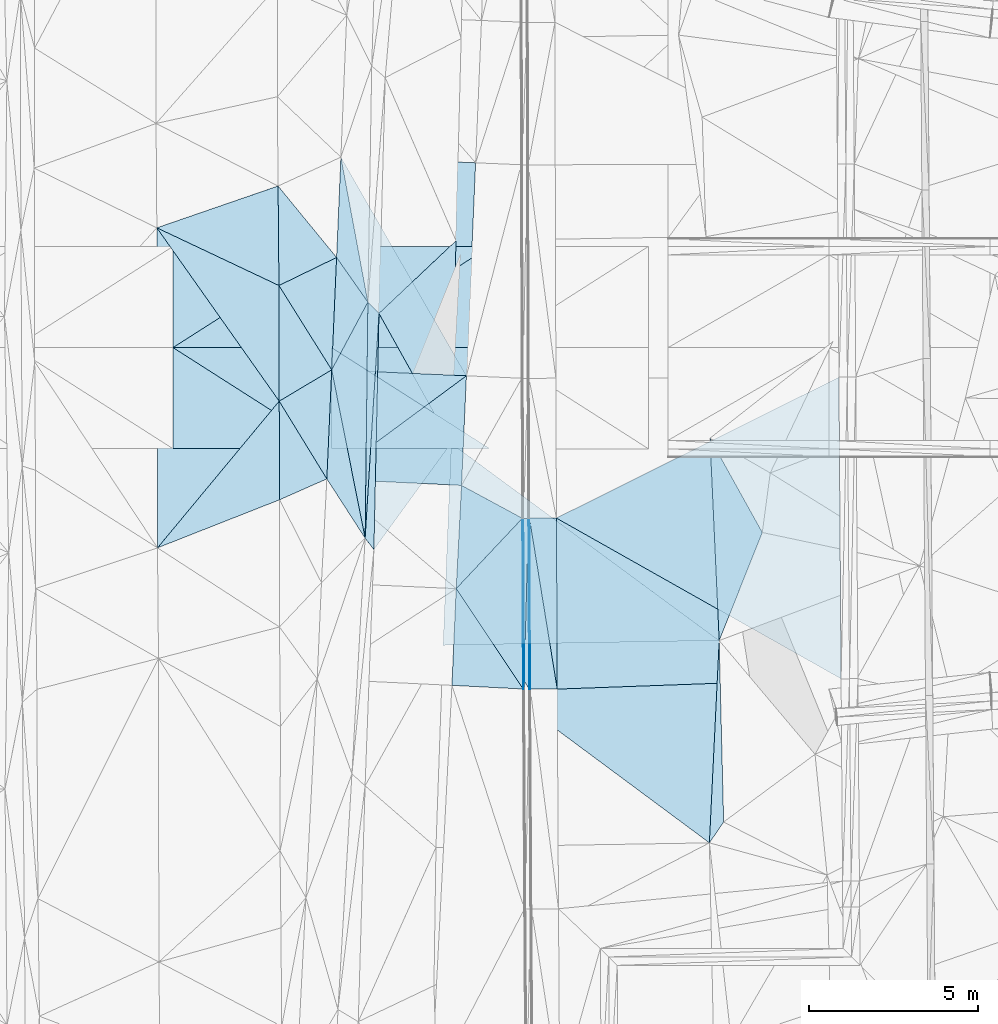
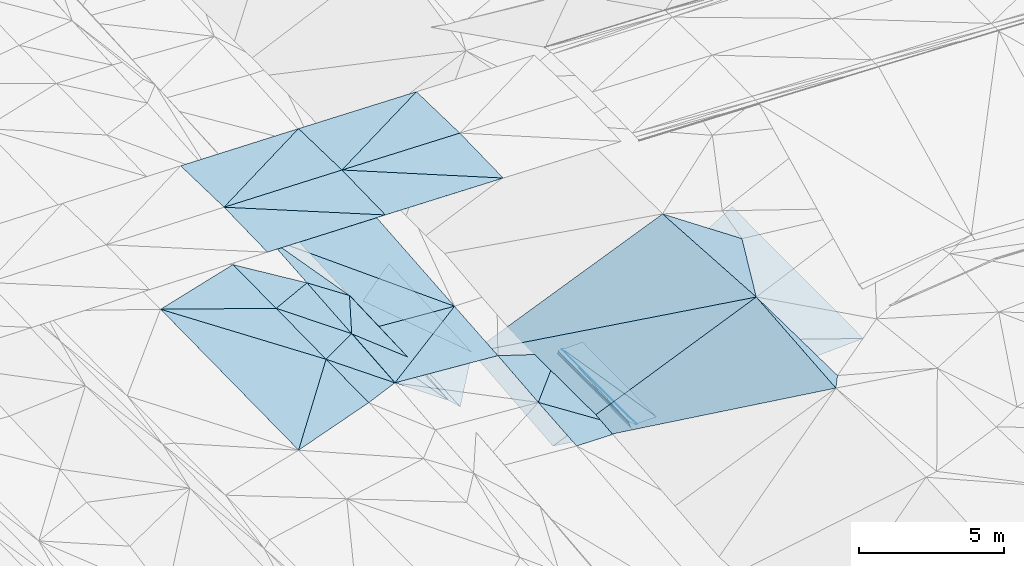
# One storey, part 96 of 275: 47 plates.
"""IFC2X3 building model written with IfcOpenShell, lengths in millimetres."""

from ifc_helpers import new_model, si_unit, frame, origin_with_axes, place, context, subcontext, project, spatial, polyline, outline, extrude, material, type_object, element, save


model = new_model("IFC2X3")

# Units and contexts
model_context = context("Model", 3, precision=1e-05, world=origin_with_axes())
body_context = subcontext(model_context, "Body", "Model", "MODEL_VIEW")
ifc_project = project(units=[si_unit("LENGTHUNIT", "METRE", prefix="MILLI"), si_unit("AREAUNIT", "SQUARE_METRE"), si_unit("VOLUMEUNIT", "CUBIC_METRE"), si_unit("MASSUNIT", "GRAM", prefix="KILO"), si_unit("TIMEUNIT", "SECOND"), si_unit("PLANEANGLEUNIT", "RADIAN"), si_unit("SOLIDANGLEUNIT", "STERADIAN"), si_unit("THERMODYNAMICTEMPERATUREUNIT", "DEGREE_CELSIUS"), si_unit("LUMINOUSINTENSITYUNIT", "LUMEN")], contexts=[model_context])

# Site, building, storey
site_placement = place(None, origin_with_axes())
site = spatial("IfcSite", under=ifc_project, at=site_placement, CompositionType="ELEMENT")
building_placement = place(site_placement, origin_with_axes())
building = spatial("IfcBuilding", under=site, at=building_placement, Name="Undefined", CompositionType="ELEMENT")
storey_placement = place(building_placement, origin_with_axes())
storey = spatial("IfcBuildingStorey", under=building, at=storey_placement, Name="Undefined", CompositionType="ELEMENT", Elevation=0.0)

# Plates
ifc_material = material()
plate_type_1 = type_object("IfcPlateType", PredefinedType="NOTDEFINED")
plate_1_placement = place(storey_placement, frame((-57543.422501909, 53163.1614883886, 42166.4393151958), z_axis=(0.031081005307814, 0.0169940351680346, -0.99937238999172), x_axis=(-0.998218742855956, 0.0514695879660527, -0.0301699009888954)))
element("IfcPlate", 1, at=plate_1_placement, inside=storey, type_object=plate_type_1, material=ifc_material, Name="00_PR", context=body_context, shape_type="SweptSolid", body=[
    extrude(outline(polyline([(0.0, 0.0), (2118.1044921875, -6.38829078525305e-09), (2137.24145507813, 2872.6474609375), (0.0, 0.0)])), frame((-8.85201319254618e-08, 2.18876761149539e-07, -0.5000001331573), z_axis=(0.0, 0.0, 1.0), x_axis=(1.0, 0.0, 0.0)), (0.0, 0.0, 1.0), 1.0),
])
plate_type_2 = type_object("IfcPlateType", PredefinedType="NOTDEFINED")
plate_2_placement = place(storey_placement, frame((-62950.6827658772, 68939.227915002, 42539.500382228), z_axis=(-0.03169918662069, 0.022843660801364, -0.99923637280114), x_axis=(0.998587986680233, -0.0419150259997993, -0.0326368419635838)))
element("IfcPlate", 2, at=plate_2_placement, inside=storey, type_object=plate_type_2, material=ifc_material, Name="00_PR", context=body_context, shape_type="SweptSolid", body=[
    extrude(outline(polyline([(0.0, 0.0), (4002.13354492188, -1.1859810911119e-08), (3999.06005859375, 6324.34912109375), (0.0, 0.0)])), frame((-8.85201319254618e-08, 2.18876761149539e-07, -0.5000001331573), z_axis=(0.0, 0.0, 1.0), x_axis=(1.0, 0.0, 0.0)), (0.0, 0.0, 1.0), 1.0),
])
plate_type_3 = type_object("IfcPlateType", PredefinedType="NOTDEFINED")
plate_3_placement = place(storey_placement, frame((-57566.8014895133, 58227.8968345423, 42252.821652203), z_axis=(0.970062529157908, 0.00866256078734789, -0.242700740757766), x_axis=(0.24268760909219, 0.0025521390305167, 0.970101134407895)))
element("IfcPlate", 3, at=plate_3_placement, inside=storey, type_object=plate_type_3, material=ifc_material, Name="00_PR", context=body_context, shape_type="SweptSolid", body=[
    extrude(outline(polyline([(0.0, 0.0), (123.607734680176, -1.38243194669485e-10), (37.2168807983398, 4822.37939453125), (0.0, 0.0)])), frame((-8.85201319254618e-08, 2.18876761149539e-07, -0.5000001331573), z_axis=(0.0, 0.0, 1.0), x_axis=(1.0, 0.0, 0.0)), (0.0, 0.0, 1.0), 1.0),
])
plate_type_4 = type_object("IfcPlateType", PredefinedType="NOTDEFINED")
plate_4_placement = place(storey_placement, frame((-57387.2881771584, 58228.6731265302, 42372.3550749499), z_axis=(-5.17628773639704e-05, 0.0170027214714135, -0.999855441943069), x_axis=(-0.0264140459897011, -0.999506605183952, -0.016995421974935)))
element("IfcPlate", 4, at=plate_4_placement, inside=storey, type_object=plate_type_4, material=ifc_material, Name="00_PR", context=body_context, shape_type="SweptSolid", body=[
    extrude(outline(polyline([(0.0, 0.0), (4825.24072265625, 1.666194293648e-09), (4.4185471534729, 149.935913085938), (0.0, 0.0)])), frame((-8.85201319254618e-08, 2.18876761149539e-07, -0.5000001331573), z_axis=(0.0, 0.0, 1.0), x_axis=(1.0, 0.0, 0.0)), (0.0, 0.0, 1.0), 1.0),
])
plate_5_placement = place(storey_placement, frame((-57514.7420254048, 53405.8131487874, 42290.348075249), z_axis=(0.000512374739449698, 0.0169878150610855, -0.999855565375108), x_axis=(0.0264140459544826, 0.999506605184821, 0.0169954219785252)))
element("IfcPlate", 5, at=plate_5_placement, inside=storey, type_object=plate_type_4, material=ifc_material, Name="00_PR", context=body_context, shape_type="SweptSolid", body=[
    extrude(outline(polyline([(0.0, 0.0), (4825.24072265625, 1.666194293648e-09), (-244.948867797852, 157.864486694336), (0.0, 0.0)])), frame((-8.85201319254618e-08, 2.18876761149539e-07, -0.5000001331573), z_axis=(0.0, 0.0, 1.0), x_axis=(1.0, 0.0, 0.0)), (0.0, 0.0, 1.0), 1.0),
])
plate_type_5 = type_object("IfcPlateType", PredefinedType="NOTDEFINED")
plate_6_placement = place(storey_placement, frame((-57357.2782605059, 58228.8013939178, 42372.955173437), z_axis=(0.0199201727534585, 0.0170759017334811, -0.999655740891564), x_axis=(0.00470861303382416, -0.999844652207322, -0.0169852999890066)))
element("IfcPlate", 6, at=plate_6_placement, inside=storey, type_object=plate_type_5, material=ifc_material, Name="00_PR", context=body_context, shape_type="SweptSolid", body=[
    extrude(outline(polyline([(0.0, 0.0), (5072.62158203125, 3.40514816343784e-09), (-0.00285750813782215, 30.0062046051025), (0.0, 0.0)])), frame((-8.85201319254618e-08, 2.18876761149539e-07, -0.5000001331573), z_axis=(0.0, 0.0, 1.0), x_axis=(1.0, 0.0, 0.0)), (0.0, 0.0, 1.0), 1.0),
])
plate_7_placement = place(storey_placement, frame((-57363.3930375372, 53156.8145658619, 42286.1951750821), z_axis=(0.01990570778941, 0.0170758385226892, -0.999656030110432), x_axis=(-0.00470861303292056, 0.999844652207386, 0.0169852999855012)))
element("IfcPlate", 7, at=plate_7_placement, inside=storey, type_object=plate_type_5, material=ifc_material, Name="00_PR", context=body_context, shape_type="SweptSolid", body=[
    extrude(outline(polyline([(0.0, 0.0), (5072.646484375, -6.50470610707998e-09), (0.0222192071378231, 30.006160736084), (0.0, 0.0)])), frame((-8.85201319254618e-08, 2.18876761149539e-07, -0.5000001331573), z_axis=(0.0, 0.0, 1.0), x_axis=(1.0, 0.0, 0.0)), (0.0, 0.0, 1.0), 1.0),
])
plate_type_6 = type_object("IfcPlateType", PredefinedType="NOTDEFINED")
plate_8_placement = place(storey_placement, frame((-59226.8680623683, 62454.4673304758, 42273.1193965442), z_axis=(-0.0331318692391955, 0.022019806860911, -0.999208390350344), x_axis=(-0.998452220315106, 0.0439548420281208, 0.0340754399842334)))
element("IfcPlate", 8, at=plate_8_placement, inside=storey, type_object=plate_type_6, material=ifc_material, Name="00_PR", context=body_context, shape_type="SweptSolid", body=[
    extrude(outline(polyline([(0.0, 0.0), (4002.32543945313, 5.51517587155104e-09), (4012.16552734375, 6316.04345703125), (0.0, 0.0)])), frame((-8.85201319254618e-08, 2.18876761149539e-07, -0.5000001331573), z_axis=(0.0, 0.0, 1.0), x_axis=(1.0, 0.0, 0.0)), (0.0, 0.0, 1.0), 1.0),
])
plate_type_7 = type_object("IfcPlateType", PredefinedType="NOTDEFINED")
plate_9_placement = place(storey_placement, frame((-59226.8681075771, 62454.4663267547, 42273.1193769358), z_axis=(-0.0332215681213128, 0.0200126804531088, -0.999247626983744), x_axis=(-0.804247836515456, -0.594108741626347, 0.0148398309750414)))
element("IfcPlate", 9, at=plate_9_placement, inside=storey, type_object=plate_type_7, material=ifc_material, Name="00_PR", context=body_context, shape_type="SweptSolid", body=[
    extrude(outline(polyline([(0.0, 0.0), (5148.3740234375, 9.10949893295765e-09), (3111.38671875, 2517.51489257813), (0.0, 0.0)])), frame((-8.85201319254618e-08, 2.18876761149539e-07, -0.5000001331573), z_axis=(0.0, 0.0, 1.0), x_axis=(1.0, 0.0, 0.0)), (0.0, 0.0, 1.0), 1.0),
])
plate_type_8 = type_object("IfcPlateType", PredefinedType="NOTDEFINED")
plate_10_placement = place(storey_placement, frame((-48178.7023094388, 62412.346601848, 42627.1131726756), z_axis=(0.0198965623516011, 0.0170739529141056, -0.999656244385277), x_axis=(0.00717861900447163, -0.999830838280169, -0.0169340560163154)))
element("IfcPlate", 10, at=plate_10_placement, inside=storey, type_object=plate_type_8, material=ifc_material, Name="00_PR", context=body_context, shape_type="SweptSolid", body=[
    extrude(outline(polyline([(0.0, 0.0), (8947.4130859375, -3.28873284161091e-09), (4123.2958984375, 8410.064453125), (0.0, 0.0)])), frame((-8.85201319254618e-08, 2.18876761149539e-07, -0.5000001331573), z_axis=(0.0, 0.0, 1.0), x_axis=(1.0, 0.0, 0.0)), (0.0, 0.0, 1.0), 1.0),
])
plate_type_9 = type_object("IfcPlateType", PredefinedType="NOTDEFINED")
plate_11_placement = place(storey_placement, frame((-56557.285949707, 58232.2299351179, 42388.955173764), z_axis=(0.0199201142362082, 0.01707817588788, -0.999655703208439), x_axis=(0.00470870499317034, -0.99984461315807, -0.016987572989571)))
element("IfcPlate", 11, at=plate_11_placement, inside=storey, type_object=plate_type_9, material=ifc_material, Name="00_PR", context=body_context, shape_type="SweptSolid", body=[
    extrude(outline(polyline([(0.0, 0.0), (5071.94287109375, -9.66247171163559e-09), (-0.0671199709177017, 800.159606933594), (0.0, 0.0)])), frame((-8.85201319254618e-08, 2.18876761149539e-07, -0.5000001331573), z_axis=(0.0, 0.0, 1.0), x_axis=(1.0, 0.0, 0.0)), (0.0, 0.0, 1.0), 1.0),
])
plate_12_placement = place(storey_placement, frame((-57333.3932574569, 53156.9678758025, 42286.7951734155), z_axis=(0.01990570778941, 0.0170758385226892, -0.999656030110432), x_axis=(-0.00470861303292056, 0.999844652207386, 0.0169852999855012)))
element("IfcPlate", 12, at=plate_12_placement, inside=storey, type_object=plate_type_9, material=ifc_material, Name="00_PR", context=body_context, shape_type="SweptSolid", body=[
    extrude(outline(polyline([(0.0, 0.0), (5072.62158203125, 3.40514816343784e-09), (0.61169171333313, 800.159851074219), (0.0, 0.0)])), frame((-8.85201319254618e-08, 2.18876761149539e-07, -0.5000001331573), z_axis=(0.0, 0.0, 1.0), x_axis=(1.0, 0.0, 0.0)), (0.0, 0.0, 1.0), 1.0),
])
plate_type_10 = type_object("IfcPlateType", PredefinedType="NOTDEFINED")
plate_13_placement = place(storey_placement, frame((-56533.4036791864, 53161.0752837046, 42302.7951735082), z_axis=(0.0198988933770571, 0.0170780831592164, -0.999656127434817), x_axis=(-0.00470870499390485, 0.999844613158034, 0.0169875729914905)))
element("IfcPlate", 13, at=plate_13_placement, inside=storey, type_object=plate_type_10, material=ifc_material, Name="00_PR", context=body_context, shape_type="SweptSolid", body=[
    extrude(outline(polyline([(0.0, 0.0), (5071.94287109375, -9.66247171163559e-09), (268.617309570313, 8421.95703125), (0.0, 0.0)])), frame((-8.85201319254618e-08, 2.18876761149539e-07, -0.5000001331573), z_axis=(0.0, 0.0, 1.0), x_axis=(1.0, 0.0, 0.0)), (0.0, 0.0, 1.0), 1.0),
])
plate_type_11 = type_object("IfcPlateType", PredefinedType="NOTDEFINED")
plate_14_placement = place(storey_placement, frame((-57514.2571233091, 53405.8089911216, 42290.7271543364), z_axis=(0.97031300291252, 0.00867317983337593, -0.24169702590323), x_axis=(-0.104742525963713, -0.885703765879199, -0.452280711905942)))
element("IfcPlate", 14, at=plate_14_placement, inside=storey, type_object=plate_type_11, material=ifc_material, Name="00_PR", context=body_context, shape_type="SweptSolid", body=[
    extrude(outline(polyline([(0.0, 0.0), (273.964813232422, 8.65838956087828e-10), (-4248.2939453125, 2282.26342773438), (0.0, 0.0)])), frame((-8.85201319254618e-08, 2.18876761149539e-07, -0.5000001331573), z_axis=(0.0, 0.0, 1.0), x_axis=(1.0, 0.0, 0.0)), (0.0, 0.0, 1.0), 1.0),
])
plate_type_12 = type_object("IfcPlateType", PredefinedType="NOTDEFINED")
plate_15_placement = place(storey_placement, frame((-63367.4366735568, 59395.772322673, 42349.5203750867), z_axis=(-0.0331540178362152, 0.0199211355243714, -0.999251699753739), x_axis=(0.804247836488412, 0.594108741662183, -0.0148398310060044)))
element("IfcPlate", 15, at=plate_15_placement, inside=storey, type_object=plate_type_12, material=ifc_material, Name="00_PR", context=body_context, shape_type="SweptSolid", body=[
    extrude(outline(polyline([(0.0, 0.0), (5148.3740234375, 9.10949893295765e-09), (3100.84399414063, 2530.52880859375), (0.0, 0.0)])), frame((-8.85201319254618e-08, 2.18876761149539e-07, -0.5000001331573), z_axis=(0.0, 0.0, 1.0), x_axis=(1.0, 0.0, 0.0)), (0.0, 0.0, 1.0), 1.0),
])
plate_type_13 = type_object("IfcPlateType", PredefinedType="NOTDEFINED")
plate_16_placement = place(storey_placement, frame((-57567.2709646403, 58227.9011385298, 42252.4433178087), z_axis=(0.0311068829844818, 0.0172670337245296, -0.999366905284213), x_axis=(-0.68491724292521, -0.727832072964979, -0.0338945999715446)))
element("IfcPlate", 16, at=plate_16_placement, inside=storey, type_object=plate_type_13, material=ifc_material, Name="00_PR", context=body_context, shape_type="SweptSolid", body=[
    extrude(outline(polyline([(0.0, 0.0), (2866.47436523438, -6.54836185276508e-10), (527.645446777344, 1982.75134277344), (0.0, 0.0)])), frame((-8.85201319254618e-08, 2.18876761149539e-07, -0.5000001331573), z_axis=(0.0, 0.0, 1.0), x_axis=(1.0, 0.0, 0.0)), (0.0, 0.0, 1.0), 1.0),
])
plate_type_14 = type_object("IfcPlateType", PredefinedType="NOTDEFINED")
plate_17_placement = place(storey_placement, frame((-59530.5685744037, 56141.589114218, 42155.2853190807), z_axis=(0.0312658129850754, 0.0171173635819324, -0.999364520484086), x_axis=(0.68491724293034, 0.72783207296017, 0.033894599971146)))
element("IfcPlate", 17, at=plate_17_placement, inside=storey, type_object=plate_type_14, material=ifc_material, Name="00_PR", context=body_context, shape_type="SweptSolid", body=[
    extrude(outline(polyline([(0.0, 0.0), (2866.47436523438, -6.54836185276508e-10), (-806.386352539063, 3488.501953125), (0.0, 0.0)])), frame((-8.85201319254618e-08, 2.18876761149539e-07, -0.5000001331573), z_axis=(0.0, 0.0, 1.0), x_axis=(1.0, 0.0, 0.0)), (0.0, 0.0, 1.0), 1.0),
])
plate_type_15 = type_object("IfcPlateType", PredefinedType="NOTDEFINED")
plate_18_placement = place(storey_placement, frame((-51730.2493647922, 54601.7923780748, 44799.5010316709), z_axis=(0.0643825779679155, -0.00388626777522607, -0.997917722348383), x_axis=(-0.0455081325727989, 0.998940644659639, -0.00682629597379633)))
element("IfcPlate", 18, at=plate_18_placement, inside=storey, type_object=plate_type_15, material=ifc_material, Name="00", context=body_context, shape_type="SweptSolid", body=[
    extrude(outline(polyline([(0.0, 0.0), (6006.18505859375, 1.06228981167078e-08), (3142.517578125, 1425.86987304688), (0.0, 0.0)])), frame((-8.85201319254618e-08, 2.18876761149539e-07, -0.5000001331573), z_axis=(0.0, 0.0, 1.0), x_axis=(1.0, 0.0, 0.0)), (0.0, 0.0, 1.0), 1.0),
])
plate_type_16 = type_object("IfcPlateType", PredefinedType="NOTDEFINED")
plate_19_placement = place(storey_placement, frame((-63078.3658798046, 65963.4929968548, 42479.5003329321), z_axis=(-0.0295994415330011, 0.0222714215108826, -0.999313692913701), x_axis=(0.573916397487466, -0.818155599567758, -0.0352332739172863)))
element("IfcPlate", 19, at=plate_19_placement, inside=storey, type_object=plate_type_16, material=ifc_material, Name="00", context=body_context, shape_type="SweptSolid", body=[
    extrude(outline(polyline([(0.0, 0.0), (1617.78894042969, -2.57205101661384e-09), (2646.45776367188, 2032.64892578125), (0.0, 0.0)])), frame((-8.85201319254618e-08, 2.18876761149539e-07, -0.5000001331573), z_axis=(0.0, 0.0, 1.0), x_axis=(1.0, 0.0, 0.0)), (0.0, 0.0, 1.0), 1.0),
])
plate_type_17 = type_object("IfcPlateType", PredefinedType="NOTDEFINED")
plate_20_placement = place(storey_placement, frame((-62950.6824021428, 68939.227258617, 42539.5003415751), z_axis=(-0.0307436325685577, 0.0214680683097768, -0.999296728254194), x_axis=(0.183044588702285, -0.982740783305995, -0.0267438100114988)))
element("IfcPlate", 20, at=plate_20_placement, inside=storey, type_object=plate_type_17, material=ifc_material, Name="00", context=body_context, shape_type="SweptSolid", body=[
    extrude(outline(polyline([(0.0, 0.0), (4374.84423828125, 5.70435076951981e-09), (2902.60864257813, 670.644104003906), (0.0, 0.0)])), frame((-8.85201319254618e-08, 2.18876761149539e-07, -0.5000001331573), z_axis=(0.0, 0.0, 1.0), x_axis=(1.0, 0.0, 0.0)), (0.0, 0.0, 1.0), 1.0),
])
plate_type_18 = type_object("IfcPlateType", PredefinedType="NOTDEFINED")
plate_21_placement = place(storey_placement, frame((-63230.6143020348, 60290.5260598626, 48834.5112211787), z_axis=(-0.0164056946686971, 0.0249897670495609, -0.999553082494995), x_axis=(-0.999865308224511, 5.74249800787707e-05, 0.0164122549174482)))
element("IfcPlate", 21, at=plate_21_placement, inside=storey, type_object=plate_type_18, material=ifc_material, Name="00_PR", context=body_context, shape_type="SweptSolid", body=[
    extrude(outline(polyline([(0.0, 0.0), (4700.6337890625, 9.69885149970651e-09), (4701.865234375, 3000.93701171875), (0.0, 0.0)])), frame((-8.85201319254618e-08, 2.18876761149539e-07, -0.5000001331573), z_axis=(0.0, 0.0, 1.0), x_axis=(1.0, 0.0, 0.0)), (0.0, 0.0, 1.0), 1.0),
])
for number, where, z_axis, x_axis, name in (
    (22, (-58530.2717067931, 66290.2320981999, 48745.0862443468), (-0.0190186426029315, -0.0249865816732146, -0.999506859391085), (-5.7277968073799e-05, -0.999687644772795, 0.0249921909375039), "00_PR"),
    (23, (-63230.4437249566, 63290.5010943905, 48909.5112436928), (-0.0190186426029315, -0.0249865816732146, -0.999506859391085), (5.72779774420735e-05, 0.999687644773175, -0.0249921909222736), "00_PR"),
):
    element("IfcPlate", number, at=place(storey_placement, frame(where, z_axis=z_axis, x_axis=x_axis)), inside=storey, type_object=plate_type_18, material=ifc_material, Name=name, context=body_context, shape_type="SweptSolid", body=[
        extrude(outline(polyline([(0.0, 0.0), (3000.9375, -1.02954800240695e-08), (3003.17260742188, 4700.85009765625), (0.0, 0.0)])), frame((-8.85201319254618e-08, 2.18876761149539e-07, -0.5000001331573), z_axis=(0.0, 0.0, 1.0), x_axis=(1.0, 0.0, 0.0)), (0.0, 0.0, 1.0), 1.0),
    ])
for number, where, z_axis, x_axis, name in (
    (24, (-63230.2705378828, 66290.5011156195, 48834.5112205392), (-0.0164085654338146, -0.0249878867924049, -0.999553082379347), (-5.7277968073799e-05, -0.999687644772795, 0.0249921909375039), "00_PR"),
    (25, (-67930.4429602772, 63290.7710249563, 48986.6592201924), (-0.0164085654338146, -0.0249878867924049, -0.999553082379347), (5.72779774420735e-05, 0.999687644773175, -0.0249921909222736), "00_PR"),
):
    element("IfcPlate", number, at=place(storey_placement, frame(where, z_axis=z_axis, x_axis=x_axis)), inside=storey, type_object=plate_type_18, material=ifc_material, Name=name, context=body_context, shape_type="SweptSolid", body=[
        extrude(outline(polyline([(0.0, 0.0), (3000.9375, -1.02954800240695e-08), (3002.86474609375, 4700.63330078125), (0.0, 0.0)])), frame((-8.85201319254618e-08, 2.18876761149539e-07, -0.5000001331573), z_axis=(0.0, 0.0, 1.0), x_axis=(1.0, 0.0, 0.0)), (0.0, 0.0, 1.0), 1.0),
    ])
for number, where, z_axis, x_axis, name in (
    (26, (-58530.6154680566, 60290.2570415009, 48745.0862434874), (-0.0190157818601353, 0.024988761145131, -0.999506859334482), (-0.999819041835124, 5.72269654439282e-05, 0.0190231519199148), "00_PR"),
    (27, (-63230.4437224018, 63290.5260817592, 48909.5112435177), (-0.0190157818601353, 0.024988761145131, -0.999506859334482), (0.999819041835124, -5.72279615117681e-05, -0.0190231519169448), "00_PR"),
):
    element("IfcPlate", number, at=place(storey_placement, frame(where, z_axis=z_axis, x_axis=x_axis)), inside=storey, type_object=plate_type_18, material=ifc_material, Name=name, context=body_context, shape_type="SweptSolid", body=[
        extrude(outline(polyline([(0.0, 0.0), (4700.8505859375, 7.67613528296351e-09), (4702.27734375, 3000.93701171875), (0.0, 0.0)])), frame((-8.85201319254618e-08, 2.18876761149539e-07, -0.5000001331573), z_axis=(0.0, 0.0, 1.0), x_axis=(1.0, 0.0, 0.0)), (0.0, 0.0, 1.0), 1.0),
    ])
plate_22_placement = place(storey_placement, frame((-67930.4429574338, 63290.7960136694, 48986.6592202172), z_axis=(-0.0164056946686971, 0.0249897670495609, -0.999553082494995), x_axis=(0.999865308224479, -5.74239653362821e-05, -0.0164122549229329)))
element("IfcPlate", 28, at=plate_22_placement, inside=storey, type_object=plate_type_18, material=ifc_material, Name="00_PR", context=body_context, shape_type="SweptSolid", body=[
    extrude(outline(polyline([(0.0, 0.0), (4700.6337890625, 9.69885149970651e-09), (4701.865234375, 3000.93701171875), (0.0, 0.0)])), frame((-8.85201319254618e-08, 2.18876761149539e-07, -0.5000001331573), z_axis=(0.0, 0.0, 1.0), x_axis=(1.0, 0.0, 0.0)), (0.0, 0.0, 1.0), 1.0),
])
plate_type_19 = type_object("IfcPlateType", PredefinedType="NOTDEFINED")
plate_23_placement = place(storey_placement, frame((-61821.2891481645, 64304.1834579537, 42280.5589304288), z_axis=(-0.47003751701198, 0.0302416941933889, -0.882128206403993), x_axis=(-0.0214625264551516, -0.999508963645156, -0.0228296200394951)))
element("IfcPlate", 29, at=plate_23_placement, inside=storey, type_object=plate_type_19, material=ifc_material, Name="00", context=body_context, shape_type="SweptSolid", body=[
    extrude(outline(polyline([(0.0, 0.0), (7008.43896484375, -3.95812094211578e-09), (6672.947265625, 302.559478759766), (0.0, 0.0)])), frame((-8.85201319254618e-08, 2.18876761149539e-07, -0.5000001331573), z_axis=(0.0, 0.0, 1.0), x_axis=(1.0, 0.0, 0.0)), (0.0, 0.0, 1.0), 1.0),
])
plate_type_20 = type_object("IfcPlateType", PredefinedType="NOTDEFINED")
plate_24_placement = place(storey_placement, frame((-52020.677254083, 48600.9546011829, 44701.5000658458), z_axis=(-0.00535935572403004, 0.0165878934871873, -0.999848048003236), x_axis=(0.0483290054063805, 0.998698302159262, 0.0163097670319585)))
element("IfcPlate", 30, at=plate_24_placement, inside=storey, type_object=plate_type_20, material=ifc_material, Name="00", context=body_context, shape_type="SweptSolid", body=[
    extrude(outline(polyline([(0.0, 0.0), (6008.66943359375, 1.15396687760949e-08), (638.599426269531, 392.490447998047), (0.0, 0.0)])), frame((-8.85201319254618e-08, 2.18876761149539e-07, -0.5000001331573), z_axis=(0.0, 0.0, 1.0), x_axis=(1.0, 0.0, 0.0)), (0.0, 0.0, 1.0), 1.0),
])
plate_type_21 = type_object("IfcPlateType", PredefinedType="NOTDEFINED")
plate_25_placement = place(storey_placement, frame((-63223.0013934845, 62630.3880502379, 42409.500455729), z_axis=(-0.0381428293351847, 0.0202352682869509, -0.999067394367198), x_axis=(0.194731881610685, -0.980476705850231, -0.0272932879925005)))
element("IfcPlate", 31, at=plate_25_placement, inside=storey, type_object=plate_type_21, material=ifc_material, Name="00", context=body_context, shape_type="SweptSolid", body=[
    extrude(outline(polyline([(0.0, 0.0), (5092.8271484375, -1.38170435093343e-08), (3144.97607421875, 772.220947265625), (0.0, 0.0)])), frame((-8.85201319254618e-08, 2.18876761149539e-07, -0.5000001331573), z_axis=(0.0, 0.0, 1.0), x_axis=(1.0, 0.0, 0.0)), (0.0, 0.0, 1.0), 1.0),
])
plate_type_22 = type_object("IfcPlateType", PredefinedType="NOTDEFINED")
plate_26_placement = place(storey_placement, frame((-62149.8900607357, 64639.8898096396, 42422.5003267709), z_axis=(-0.029146139573007, 0.0220294713087413, -0.999332379612433), x_axis=(-0.0116160974671641, -0.999697070031031, -0.0216987200314869)))
element("IfcPlate", 32, at=plate_26_placement, inside=storey, type_object=plate_type_22, material=ifc_material, Name="00", context=body_context, shape_type="SweptSolid", body=[
    extrude(outline(polyline([(0.0, 0.0), (7005.021484375, 2.1143932826817e-08), (2021.63952636719, 1050.14025878906), (0.0, 0.0)])), frame((-8.85201319254618e-08, 2.18876761149539e-07, -0.5000001331573), z_axis=(0.0, 0.0, 1.0), x_axis=(1.0, 0.0, 0.0)), (0.0, 0.0, 1.0), 1.0),
])
plate_type_23 = type_object("IfcPlateType", PredefinedType="NOTDEFINED")
plate_27_placement = place(storey_placement, frame((-62231.4340933103, 57636.9917308327, 42270.5366745083), z_axis=(-0.375176197443002, 0.024472190620312, -0.926630418645132), x_axis=(0.0116160974802961, 0.999697070032008, 0.0216987199794335)))
element("IfcPlate", 33, at=plate_27_placement, inside=storey, type_object=plate_type_23, material=ifc_material, Name="00", context=body_context, shape_type="SweptSolid", body=[
    extrude(outline(polyline([(0.0, 0.0), (7005.021484375, 2.1143932826817e-08), (6670.15087890625, 358.9580078125), (0.0, 0.0)])), frame((-8.85201319254618e-08, 2.18876761149539e-07, -0.5000001331573), z_axis=(0.0, 0.0, 1.0), x_axis=(1.0, 0.0, 0.0)), (0.0, 0.0, 1.0), 1.0),
])
plate_type_24 = type_object("IfcPlateType", PredefinedType="NOTDEFINED")
plate_28_placement = place(storey_placement, frame((-63222.9980111179, 62630.3880944803, 42409.5003422572), z_axis=(-0.0313758641808913, 0.0203262907377129, -0.999300954193354), x_axis=(-0.858679197762185, -0.512246445469311, 0.0165412948267589)))
element("IfcPlate", 34, at=plate_28_placement, inside=storey, type_object=plate_type_24, material=ifc_material, Name="00", context=body_context, shape_type="SweptSolid", body=[
    extrude(outline(polyline([(0.0, 0.0), (1813.64270019531, -2.459273673594e-09), (64.2905044555664, 2951.044921875), (0.0, 0.0)])), frame((-8.85201319254618e-08, 2.18876761149539e-07, -0.5000001331573), z_axis=(0.0, 0.0, 1.0), x_axis=(1.0, 0.0, 0.0)), (0.0, 0.0, 1.0), 1.0),
])
plate_type_25 = type_object("IfcPlateType", PredefinedType="NOTDEFINED")
plate_29_placement = place(storey_placement, frame((-64780.3351871492, 61701.3558494152, 42439.5003305596), z_axis=(-0.0311380226033, 0.0199270968392166, -0.999316433548412), x_axis=(0.858679197710562, 0.512246445556215, -0.0165412948153534)))
element("IfcPlate", 35, at=plate_29_placement, inside=storey, type_object=plate_type_25, material=ifc_material, Name="00", context=body_context, shape_type="SweptSolid", body=[
    extrude(outline(polyline([(0.0, 0.0), (1813.64270019531, -2.459273673594e-09), (33.6891059875488, 2705.35864257813), (0.0, 0.0)])), frame((-8.85201319254618e-08, 2.18876761149539e-07, -0.5000001331573), z_axis=(0.0, 0.0, 1.0), x_axis=(1.0, 0.0, 0.0)), (0.0, 0.0, 1.0), 1.0),
])
plate_type_26 = type_object("IfcPlateType", PredefinedType="NOTDEFINED")
plate_30_placement = place(storey_placement, frame((-63078.3647371801, 65963.4919006562, 42479.5002773477), z_axis=(-0.0273148237231366, 0.0200781593166585, -0.999425218774986), x_axis=(-0.898988401120144, -0.437688184763268, 0.015776804812242)))
element("IfcPlate", 36, at=plate_30_placement, inside=storey, type_object=plate_type_26, material=ifc_material, Name="00", context=body_context, shape_type="SweptSolid", body=[
    extrude(outline(polyline([(0.0, 0.0), (1901.52575683594, 2.70665623247623e-09), (633.649047851563, 2666.28735351563), (0.0, 0.0)])), frame((-8.85201319254618e-08, 2.18876761149539e-07, -0.5000001331573), z_axis=(0.0, 0.0, 1.0), x_axis=(1.0, 0.0, 0.0)), (0.0, 0.0, 1.0), 1.0),
])
plate_type_27 = type_object("IfcPlateType", PredefinedType="NOTDEFINED")
plate_31_placement = place(storey_placement, frame((-63367.4354169154, 59395.7725734545, 42349.5003245444), z_axis=(-0.0304267665922197, 0.020363477521087, -0.999329545574427), x_axis=(-0.914431392006575, -0.404265889686148, 0.0196040748107327)))
element("IfcPlate", 37, at=plate_31_placement, inside=storey, type_object=plate_type_27, material=ifc_material, Name="00", context=body_context, shape_type="SweptSolid", body=[
    extrude(outline(polyline([(0.0, 0.0), (1530.29406738281, 3.36149241775274e-09), (361.695190429688, 2681.28271484375), (0.0, 0.0)])), frame((-8.85201319254618e-08, 2.18876761149539e-07, -0.5000001331573), z_axis=(0.0, 0.0, 1.0), x_axis=(1.0, 0.0, 0.0)), (0.0, 0.0, 1.0), 1.0),
])
plate_type_28 = type_object("IfcPlateType", PredefinedType="NOTDEFINED")
plate_32_placement = place(storey_placement, frame((-64787.8148071689, 65131.2176387617, 42509.5003136051), z_axis=(-0.0283554479777728, 0.0222182236657555, -0.999350948919907), x_axis=(0.898988401123047, 0.437688184757454, -0.0157768048080671)))
element("IfcPlate", 38, at=plate_32_placement, inside=storey, type_object=plate_type_28, material=ifc_material, Name="00", context=body_context, shape_type="SweptSolid", body=[
    extrude(outline(polyline([(0.0, 0.0), (1901.52575683594, 2.70665623247623e-09), (313.748046875, 2935.0234375), (0.0, 0.0)])), frame((-8.85201319254618e-08, 2.18876761149539e-07, -0.5000001331573), z_axis=(0.0, 0.0, 1.0), x_axis=(1.0, 0.0, 0.0)), (0.0, 0.0, 1.0), 1.0),
])
plate_type_29 = type_object("IfcPlateType", PredefinedType="NOTDEFINED")
plate_33_placement = place(storey_placement, frame((-64787.82212246, 65131.2164950568, 42509.5005506213), z_axis=(-0.0429851237431285, 0.0199306746474728, -0.998876892987762), x_axis=(-0.903063709679461, 0.426885355618525, 0.0473796308387362)))
element("IfcPlate", 39, at=plate_33_placement, inside=storey, type_object=plate_type_29, material=ifc_material, Name="00", context=body_context, shape_type="SweptSolid", body=[
    extrude(outline(polyline([(0.0, 0.0), (4010.162109375, -8.76752892509103e-09), (1286.05773925781, 2657.56567382813), (0.0, 0.0)])), frame((-8.85201319254618e-08, 2.18876761149539e-07, -0.5000001331573), z_axis=(0.0, 0.0, 1.0), x_axis=(1.0, 0.0, 0.0)), (0.0, 0.0, 1.0), 1.0),
])
plate_type_30 = type_object("IfcPlateType", PredefinedType="NOTDEFINED")
plate_34_placement = place(storey_placement, frame((-64780.341536253, 61701.3560316198, 42439.5005725387), z_axis=(-0.0438354840231295, 0.0202911491149663, -0.998832678484266), x_axis=(0.0046328326352634, -0.999778838235478, -0.0205136900213178)))
element("IfcPlate", 40, at=plate_34_placement, inside=storey, type_object=plate_type_30, material=ifc_material, Name="00", context=body_context, shape_type="SweptSolid", body=[
    extrude(outline(polyline([(0.0, 0.0), (2924.8759765625, 4.22005541622639e-10), (4331.6708984375, 3632.56494140625), (0.0, 0.0)])), frame((-8.85201319254618e-08, 2.18876761149539e-07, -0.5000001331573), z_axis=(0.0, 0.0, 1.0), x_axis=(1.0, 0.0, 0.0)), (0.0, 0.0, 1.0), 1.0),
])
plate_type_31 = type_object("IfcPlateType", PredefinedType="NOTDEFINED")
plate_35_placement = place(storey_placement, frame((-68389.3076662312, 57350.5671984757, 42509.5005572161), z_axis=(-0.0433666737916922, 0.019901817308361, -0.99886097594814), x_axis=(-0.00210085862642633, 0.999797538852753, 0.0200116890094312)))
element("IfcPlate", 41, at=plate_35_placement, inside=storey, type_object=plate_type_31, material=ifc_material, Name="00", context=body_context, shape_type="SweptSolid", body=[
    extrude(outline(polyline([(0.0, 0.0), (9494.451171875, -5.86442183703184e-09), (4340.9248046875, 3621.5009765625), (0.0, 0.0)])), frame((-8.85201319254618e-08, 2.18876761149539e-07, -0.5000001331573), z_axis=(0.0, 0.0, 1.0), x_axis=(1.0, 0.0, 0.0)), (0.0, 0.0, 1.0), 1.0),
])
plate_type_32 = type_object("IfcPlateType", PredefinedType="NOTDEFINED")
plate_36_placement = place(storey_placement, frame((-64780.3410256204, 61701.356030952, 42439.5005507474), z_axis=(-0.04281399993102, 0.0202926885813796, -0.998876953483284), x_axis=(-0.576133327435894, 0.816312750519008, 0.0412781099099414)))
element("IfcPlate", 42, at=plate_36_placement, inside=storey, type_object=plate_type_32, material=ifc_material, Name="00", context=body_context, shape_type="SweptSolid", body=[
    extrude(outline(polyline([(0.0, 0.0), (6298.73779296875, -9.18953446671367e-09), (2807.03857421875, 1972.1650390625), (0.0, 0.0)])), frame((-8.85201319254618e-08, 2.18876761149539e-07, -0.5000001331573), z_axis=(0.0, 0.0, 1.0), x_axis=(1.0, 0.0, 0.0)), (0.0, 0.0, 1.0), 1.0),
])
plate_type_33 = type_object("IfcPlateType", PredefinedType="NOTDEFINED")
plate_37_placement = place(storey_placement, frame((-61821.1620957143, 64304.1818022373, 42280.5119761131), z_axis=(-0.215932086677987, 0.0269302248827667, -0.976036934204159), x_axis=(0.481957305678163, -0.866417262076054, -0.130530775988193)))
element("IfcPlate", 43, at=plate_37_placement, inside=storey, type_object=plate_type_33, material=ifc_material, Name="00", context=body_context, shape_type="SweptSolid", body=[
    extrude(outline(polyline([(0.0, 0.0), (4443.396484375, 5.2677933126688e-09), (6017.64013671875, 3592.52294921875), (0.0, 0.0)])), frame((-8.85201319254618e-08, 2.18876761149539e-07, -0.5000001331573), z_axis=(0.0, 0.0, 1.0), x_axis=(1.0, 0.0, 0.0)), (0.0, 0.0, 1.0), 1.0),
])
plate_type_34 = type_object("IfcPlateType", PredefinedType="NOTDEFINED")
plate_38_placement = place(storey_placement, frame((-59536.3685434732, 66459.0307079786, 41755.5142816305), z_axis=(-0.236934682435903, 0.0145511434232559, -0.971416605007385), x_axis=(-0.0238529934780836, -0.999673543171579, -0.00915651598129823)))
element("IfcPlate", 44, at=plate_38_placement, inside=storey, type_object=plate_type_34, material=ifc_material, Name="00", context=body_context, shape_type="SweptSolid", body=[
    extrude(outline(polyline([(0.0, 0.0), (6006.6513671875, 2.77359504252672e-08), (2203.84375, 2298.35327148438), (0.0, 0.0)])), frame((-8.85201319254618e-08, 2.18876761149539e-07, -0.5000001331573), z_axis=(0.0, 0.0, 1.0), x_axis=(1.0, 0.0, 0.0)), (0.0, 0.0, 1.0), 1.0),
])
plate_type_35 = type_object("IfcPlateType", PredefinedType="NOTDEFINED")
plate_39_placement = place(storey_placement, frame((-59918.3401992739, 54460.9081709899, 41465.536948427), z_axis=(0.376707748180708, 0.0212894111635186, -0.92608748692169), x_axis=(0.0398150584464151, 0.998439865173461, 0.0391483940067791)))
element("IfcPlate", 45, at=plate_39_placement, inside=storey, type_object=plate_type_35, material=ifc_material, Name="00", context=body_context, shape_type="SweptSolid", body=[
    extrude(outline(polyline([(0.0, 0.0), (6002.80029296875, -1.07393134385347e-08), (597.213256835938, 8821.912109375), (0.0, 0.0)])), frame((-8.85201319254618e-08, 2.18876761149539e-07, -0.5000001331573), z_axis=(0.0, 0.0, 1.0), x_axis=(1.0, 0.0, 0.0)), (0.0, 0.0, 1.0), 1.0),
])
plate_type_36 = type_object("IfcPlateType", PredefinedType="NOTDEFINED")
plate_40_placement = place(storey_placement, frame((-51730.0930270078, 54601.7927549121, 44799.5369210229), z_axis=(0.377151775126645, -0.00312621099398869, -0.926146190038938), x_axis=(-0.0483290054332966, -0.998698302158307, -0.0163097670107058)))
element("IfcPlate", 46, at=plate_40_placement, inside=storey, type_object=plate_type_36, material=ifc_material, Name="00", context=body_context, shape_type="SweptSolid", body=[
    extrude(outline(polyline([(0.0, 0.0), (6008.66943359375, 1.15396687760949e-08), (590.820007324219, 8822.3427734375), (0.0, 0.0)])), frame((-8.85201319254618e-08, 2.18876761149539e-07, -0.5000001331573), z_axis=(0.0, 0.0, 1.0), x_axis=(1.0, 0.0, 0.0)), (0.0, 0.0, 1.0), 1.0),
])
plate_type_37 = type_object("IfcPlateType", PredefinedType="NOTDEFINED")
plate_41_placement = place(storey_placement, frame((-52003.4269215006, 60601.6221145264, 44758.5354883697), z_axis=(0.369905788251353, 0.0105031516549465, -0.929009898560537), x_axis=(0.045508132577819, -0.998940644659132, 0.00682629601441978)))
element("IfcPlate", 47, at=plate_41_placement, inside=storey, type_object=plate_type_37, material=ifc_material, Name="00", context=body_context, shape_type="SweptSolid", body=[
    extrude(outline(polyline([(0.0, 0.0), (6006.18505859375, 1.06228981167078e-08), (-223.063385009766, 8260.9306640625), (0.0, 0.0)])), frame((-8.85201319254618e-08, 2.18876761149539e-07, -0.5000001331573), z_axis=(0.0, 0.0, 1.0), x_axis=(1.0, 0.0, 0.0)), (0.0, 0.0, 1.0), 1.0),
])

save(model, "model.ifc")
